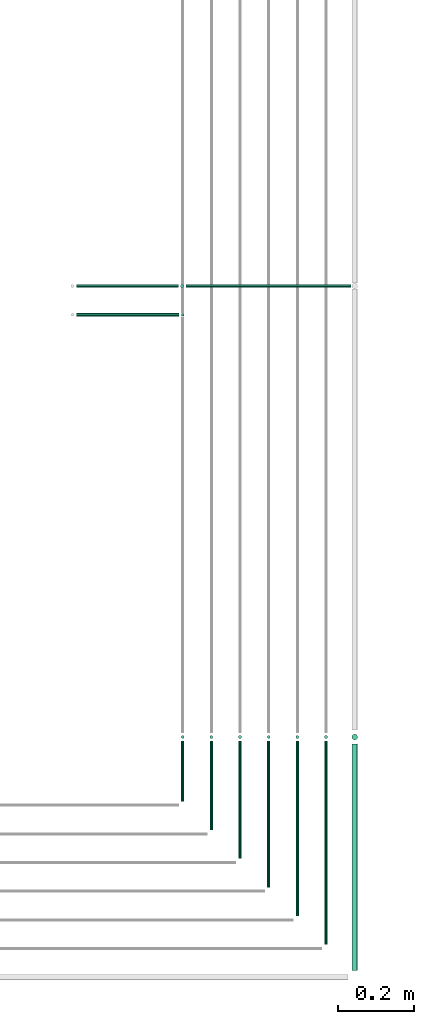
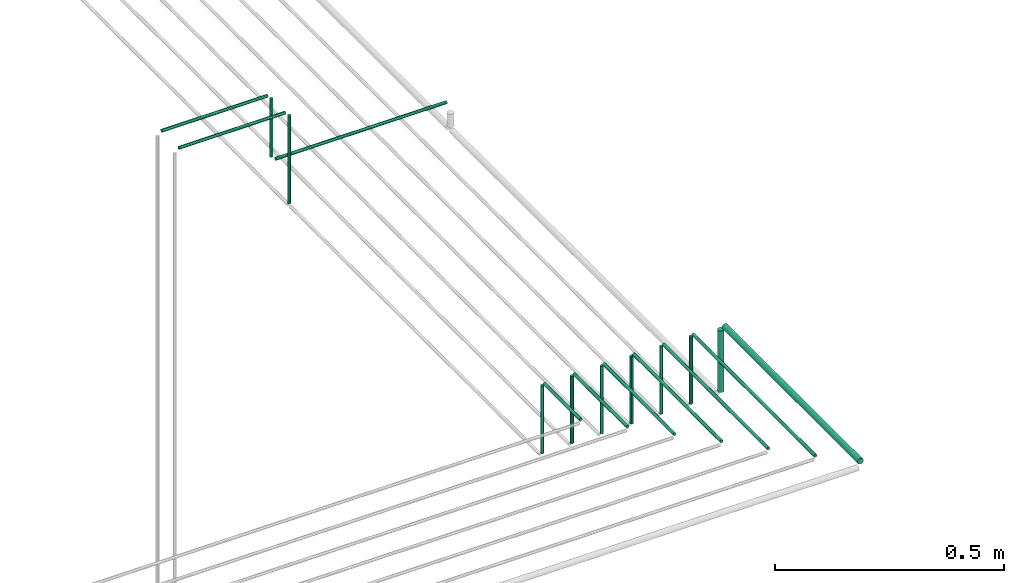
# One storey, part 47 of 89: 19 flow segments.
"""IFC2X3 building model written with IfcOpenShell, lengths in millimetres."""

from ifc_helpers import new_model, entity, si_unit, converted_unit, derived_unit, direction, frame, frame_2d, origin, origin_2d_with_axis, place, context, subcontext, project, spatial, circle, extrude, type_object, element, save


model = new_model("IFC2X3")

# Units and contexts
model_context = context("Model", 3, precision=0.01, world=origin(), true_north=direction((6.12303176911189e-17, 1.0)))
body_context = subcontext(model_context, "Body", "Model", "MODEL_VIEW")
ifc_project = project(units=[si_unit("LENGTHUNIT", "METRE", prefix="MILLI"), si_unit("AREAUNIT", "SQUARE_METRE"), si_unit("VOLUMEUNIT", "CUBIC_METRE"), converted_unit("PLANEANGLEUNIT", "DEGREE", entity("IfcRatioMeasure", 0.0174532925199433), si_unit("PLANEANGLEUNIT", "RADIAN"), dimensions=[0, 0, 0, 0, 0, 0, 0]), si_unit("MASSUNIT", "GRAM", prefix="KILO"), derived_unit("MASSDENSITYUNIT", [(si_unit("MASSUNIT", "GRAM", prefix="KILO"), 1), (si_unit("LENGTHUNIT", "METRE"), -3)]), derived_unit("MOMENTOFINERTIAUNIT", [(si_unit("LENGTHUNIT", "METRE"), 4)]), si_unit("TIMEUNIT", "SECOND"), si_unit("FREQUENCYUNIT", "HERTZ"), si_unit("THERMODYNAMICTEMPERATUREUNIT", "DEGREE_CELSIUS"), derived_unit("THERMALTRANSMITTANCEUNIT", [(si_unit("MASSUNIT", "GRAM", prefix="KILO"), 1), (si_unit("THERMODYNAMICTEMPERATUREUNIT", "KELVIN"), -1), (si_unit("TIMEUNIT", "SECOND"), -3)]), derived_unit("VOLUMETRICFLOWRATEUNIT", [(si_unit("LENGTHUNIT", "METRE"), 3), (si_unit("TIMEUNIT", "SECOND"), -1)]), derived_unit("MASSFLOWRATEUNIT", [(si_unit("MASSUNIT", "GRAM", prefix="KILO"), 1), (si_unit("TIMEUNIT", "SECOND"), -1)]), derived_unit("ROTATIONALFREQUENCYUNIT", [(si_unit("TIMEUNIT", "SECOND"), -1)]), si_unit("ELECTRICCURRENTUNIT", "AMPERE"), si_unit("ELECTRICVOLTAGEUNIT", "VOLT"), si_unit("POWERUNIT", "WATT"), si_unit("FORCEUNIT", "NEWTON", prefix="KILO"), si_unit("ILLUMINANCEUNIT", "LUX"), si_unit("LUMINOUSFLUXUNIT", "LUMEN"), si_unit("LUMINOUSINTENSITYUNIT", "CANDELA"), derived_unit("USERDEFINED", [(si_unit("MASSUNIT", "GRAM", prefix="KILO"), -1), (si_unit("LENGTHUNIT", "METRE"), -2), (si_unit("TIMEUNIT", "SECOND"), 3), (si_unit("LUMINOUSFLUXUNIT", "LUMEN"), 1)]), derived_unit("LINEARVELOCITYUNIT", [(si_unit("LENGTHUNIT", "METRE"), 1), (si_unit("TIMEUNIT", "SECOND"), -1)]), si_unit("PRESSUREUNIT", "PASCAL"), derived_unit("USERDEFINED", [(si_unit("LENGTHUNIT", "METRE"), -2), (si_unit("MASSUNIT", "GRAM", prefix="KILO"), 1), (si_unit("TIMEUNIT", "SECOND"), -2)]), derived_unit("LINEARFORCEUNIT", [(si_unit("MASSUNIT", "GRAM", prefix="KILO"), 1), (si_unit("LENGTHUNIT", "METRE"), 1), (si_unit("TIMEUNIT", "SECOND"), -2), (si_unit("LENGTHUNIT", "METRE"), -1)]), derived_unit("PLANARFORCEUNIT", [(si_unit("MASSUNIT", "GRAM", prefix="KILO"), 1), (si_unit("LENGTHUNIT", "METRE"), 1), (si_unit("TIMEUNIT", "SECOND"), -2), (si_unit("LENGTHUNIT", "METRE"), -2)])], contexts=[model_context])

# Site, building, storey
site_placement = place(None, frame((0.0, -0.00077364408347762, 0.0)))
site = spatial("IfcSite", under=ifc_project, at=site_placement, CompositionType="ELEMENT")
building_placement = place(site_placement, origin())
building = spatial("IfcBuilding", under=site, at=building_placement, CompositionType="ELEMENT")
storey_placement = place(building_placement, frame((0.0, 0.0, 24000.0)))
storey = spatial("IfcBuildingStorey", under=building, at=storey_placement, CompositionType="ELEMENT", Elevation=24000.0)

# Flow segments
pipe_segment_type = type_object("IfcPipeSegmentType", PredefinedType="NOTDEFINED")
flow_segment_1_placement = place(storey_placement, frame((66941.4633506707, 2902.64530556803, 3044.40472776411)))
element("IfcFlowSegment", 1, at=flow_segment_1_placement, inside=storey, type_object=pipe_segment_type, context=body_context, shape_type="SweptSolid", body=[
    extrude(circle(Radius=4.0, at=frame_2d((-1.62430069394759e-12, 0.0), x_axis=(1.0, 0.0))), frame((0.0, 5.5952722359177, 5.59527223591499), z_axis=(1.0, 0.0, 0.0), x_axis=(0.0, 1.0, 0.0)), (0.0, 0.0, 1.0), 268.536917884121),
])
flow_segment_2_placement = place(storey_placement, frame((67214.4049963189, 2902.64530556802, 2805.0)))
element("IfcFlowSegment", 2, at=flow_segment_2_placement, inside=storey, type_object=pipe_segment_type, context=body_context, shape_type="SweptSolid", body=[
    extrude(circle(Radius=4.0, at=origin_2d_with_axis()), frame((5.59527223591499, 5.59527223591607, 0.0), z_axis=(0.0, 0.0, 1.0), x_axis=(-1.0, 0.0, 0.0)), (0.0, 0.0, 1.0), 235.000000000012),
])
flow_segment_3_placement = place(storey_placement, frame((67228.3966700427, 2977.64530556803, 2869.4047277641)))
element("IfcFlowSegment", 3, at=flow_segment_3_placement, inside=storey, type_object=pipe_segment_type, context=body_context, shape_type="SweptSolid", body=[
    extrude(circle(Radius=4.0, at=frame_2d((-1.62430069394759e-12, 0.0), x_axis=(1.0, 0.0))), frame((0.0, 5.5952722359177, 5.59527223591499), z_axis=(1.0, 0.0, 0.0), x_axis=(0.0, 1.0, 0.0)), (0.0, 0.0, 1.0), 431.603598512165),
])
flow_segment_4_placement = place(storey_placement, frame((66941.4633506707, 2977.64530556803, 3044.4047277641)))
element("IfcFlowSegment", 4, at=flow_segment_4_placement, inside=storey, type_object=pipe_segment_type, context=body_context, shape_type="SweptSolid", body=[
    extrude(circle(Radius=4.0, at=origin_2d_with_axis()), frame((0.0, 5.5952722359204, 5.59527223591499), z_axis=(1.0, 0.0, 0.0), x_axis=(0.0, -1.0, 0.0)), (0.0, 0.0, 1.0), 266.933319371988),
])
flow_segment_5_placement = place(storey_placement, frame((67212.8013978068, 2977.64530556803, 2885.0)))
element("IfcFlowSegment", 5, at=flow_segment_5_placement, inside=storey, type_object=pipe_segment_type, context=body_context, shape_type="SweptSolid", body=[
    extrude(circle(Radius=4.0, at=origin_2d_with_axis()), frame((5.59527223591499, 5.59527223591607, 0.0)), (0.0, 0.0, 1.0), 154.999999999999),
])
flow_segment_6_placement = place(storey_placement, frame((67214.4049963189, 1634.95129953587, 2994.4047277641)))
element("IfcFlowSegment", 6, at=flow_segment_6_placement, inside=storey, type_object=pipe_segment_type, context=body_context, shape_type="SweptSolid", body=[
    extrude(circle(Radius=4.0, at=frame_2d((8.66293703438714e-12, 0.0), x_axis=(1.0, 0.0))), frame((5.59527223592365, 0.0, 5.59527223591499), z_axis=(0.0, 1.0, 0.0), x_axis=(-1.0, 0.0, 0.0)), (0.0, 0.0, 1.0), 158.289278268077),
])
flow_segment_7_placement = place(storey_placement, frame((67214.4049963189, 1797.64530556802, 2810.0)))
element("IfcFlowSegment", 7, at=flow_segment_7_placement, inside=storey, type_object=pipe_segment_type, context=body_context, shape_type="SweptSolid", body=[
    extrude(circle(Radius=4.0, at=origin_2d_with_axis()), frame((5.59527223591499, 5.5952722359158, 0.0), z_axis=(0.0, 0.0, 1.0), x_axis=(-1.0, 0.0, 0.0)), (0.0, 0.0, 1.0), 180.000000000015),
])
flow_segment_8_placement = place(storey_placement, frame((67289.4049963189, 1559.95129953583, 2994.4047277641)))
element("IfcFlowSegment", 8, at=flow_segment_8_placement, inside=storey, type_object=pipe_segment_type, context=body_context, shape_type="SweptSolid", body=[
    extrude(circle(Radius=4.0, at=origin_2d_with_axis()), frame((5.59527223591499, 0.0, 5.59527223591499), z_axis=(0.0, 1.0, 0.0), x_axis=(-1.0, 0.0, 0.0)), (0.0, 0.0, 1.0), 233.289278268112),
])
flow_segment_9_placement = place(storey_placement, frame((67289.4049963189, 1797.64530556802, 2810.0)))
element("IfcFlowSegment", 9, at=flow_segment_9_placement, inside=storey, type_object=pipe_segment_type, context=body_context, shape_type="SweptSolid", body=[
    extrude(circle(Radius=4.0, at=origin_2d_with_axis()), frame((5.59527223591499, 5.5952722359158, 0.0), z_axis=(0.0, 0.0, 1.0), x_axis=(-1.0, 0.0, 0.0)), (0.0, 0.0, 1.0), 180.000000000015),
])
flow_segment_10_placement = place(storey_placement, frame((67364.4049963189, 1484.95129953586, 2994.4047277641)))
element("IfcFlowSegment", 10, at=flow_segment_10_placement, inside=storey, type_object=pipe_segment_type, context=body_context, shape_type="SweptSolid", body=[
    extrude(circle(Radius=4.0, at=frame_2d((8.66293703438714e-12, 0.0), x_axis=(1.0, 0.0))), frame((5.59527223591499, 0.0, 5.59527223591499), z_axis=(0.0, 1.0, 0.0), x_axis=(-1.0, 0.0, 0.0)), (0.0, 0.0, 1.0), 308.289278268086),
])
flow_segment_11_placement = place(storey_placement, frame((67364.4049963189, 1797.64530556802, 2810.0)))
element("IfcFlowSegment", 11, at=flow_segment_11_placement, inside=storey, type_object=pipe_segment_type, context=body_context, shape_type="SweptSolid", body=[
    extrude(circle(Radius=4.0, at=origin_2d_with_axis()), frame((5.59527223591499, 5.5952722359158, 0.0), z_axis=(0.0, 0.0, 1.0), x_axis=(-1.0, 0.0, 0.0)), (0.0, 0.0, 1.0), 180.000000000015),
])
flow_segment_12_placement = place(storey_placement, frame((67439.4049963189, 1409.95129953582, 2994.4047277641)))
element("IfcFlowSegment", 12, at=flow_segment_12_placement, inside=storey, type_object=pipe_segment_type, context=body_context, shape_type="SweptSolid", body=[
    extrude(circle(Radius=4.0, at=origin_2d_with_axis()), frame((5.59527223591499, 0.0, 5.59527223591499), z_axis=(0.0, 1.0, 0.0), x_axis=(-1.0, 0.0, 0.0)), (0.0, 0.0, 1.0), 383.289278268121),
])
flow_segment_13_placement = place(storey_placement, frame((67439.4049963189, 1797.64530556802, 2810.0)))
element("IfcFlowSegment", 13, at=flow_segment_13_placement, inside=storey, type_object=pipe_segment_type, context=body_context, shape_type="SweptSolid", body=[
    extrude(circle(Radius=4.0, at=origin_2d_with_axis()), frame((5.59527223591499, 5.5952722359158, 0.0), z_axis=(0.0, 0.0, 1.0), x_axis=(-1.0, 0.0, 0.0)), (0.0, 0.0, 1.0), 180.000000000015),
])
flow_segment_14_placement = place(storey_placement, frame((67514.4049963189, 1334.95129953585, 2994.4047277641)))
element("IfcFlowSegment", 14, at=flow_segment_14_placement, inside=storey, type_object=pipe_segment_type, context=body_context, shape_type="SweptSolid", body=[
    extrude(circle(Radius=4.0, at=origin_2d_with_axis()), frame((5.59527223591499, 0.0, 5.59527223591499), z_axis=(0.0, 1.0, 0.0), x_axis=(-1.0, 0.0, 0.0)), (0.0, 0.0, 1.0), 458.28927826809),
])
flow_segment_15_placement = place(storey_placement, frame((67514.4049963189, 1797.64530556802, 2810.0)))
element("IfcFlowSegment", 15, at=flow_segment_15_placement, inside=storey, type_object=pipe_segment_type, context=body_context, shape_type="SweptSolid", body=[
    extrude(circle(Radius=4.0, at=origin_2d_with_axis()), frame((5.59527223591499, 5.5952722359158, 0.0), z_axis=(0.0, 0.0, 1.0), x_axis=(-1.0, 0.0, 0.0)), (0.0, 0.0, 1.0), 180.000000000015),
])
flow_segment_16_placement = place(storey_placement, frame((67589.4049963189, 1259.95129953582, 2994.4047277641)))
element("IfcFlowSegment", 16, at=flow_segment_16_placement, inside=storey, type_object=pipe_segment_type, context=body_context, shape_type="SweptSolid", body=[
    extrude(circle(Radius=4.0, at=origin_2d_with_axis()), frame((5.59527223591499, 0.0, 5.59527223591499), z_axis=(0.0, 1.0, 0.0), x_axis=(-1.0, 0.0, 0.0)), (0.0, 0.0, 1.0), 533.289278268125),
])
flow_segment_17_placement = place(storey_placement, frame((67589.4049963189, 1797.64530556802, 2810.0)))
element("IfcFlowSegment", 17, at=flow_segment_17_placement, inside=storey, type_object=pipe_segment_type, context=body_context, shape_type="SweptSolid", body=[
    extrude(circle(Radius=4.0, at=origin_2d_with_axis()), frame((5.59527223591499, 5.5952722359158, 0.0), z_axis=(0.0, 0.0, 1.0), x_axis=(-1.0, 0.0, 0.0)), (0.0, 0.0, 1.0), 180.000000000015),
])
flow_segment_18_placement = place(storey_placement, frame((67660.9049963189, 1192.95129953582, 2990.9047277641)))
element("IfcFlowSegment", 18, at=flow_segment_18_placement, inside=storey, type_object=pipe_segment_type, context=body_context, shape_type="SweptSolid", body=[
    extrude(circle(Radius=7.5, at=origin_2d_with_axis()), frame((9.09527223592286, 0.0, 9.09527223591419), z_axis=(0.0, 1.0, 0.0), x_axis=(-1.0, 0.0, 0.0)), (0.0, 0.0, 1.0), 592.289278268128),
])
flow_segment_19_placement = place(storey_placement, frame((67660.9049963189, 1794.14530556802, 2818.0)))
element("IfcFlowSegment", 19, at=flow_segment_19_placement, inside=storey, type_object=pipe_segment_type, context=body_context, shape_type="SweptSolid", body=[
    extrude(circle(Radius=7.5, at=origin_2d_with_axis()), frame((9.09527223591419, 9.09527223591582, 0.0), z_axis=(0.0, 0.0, 1.0), x_axis=(-1.0, 0.0, 0.0)), (0.0, 0.0, 1.0), 164.000000000015),
])

save(model, "model.ifc")
